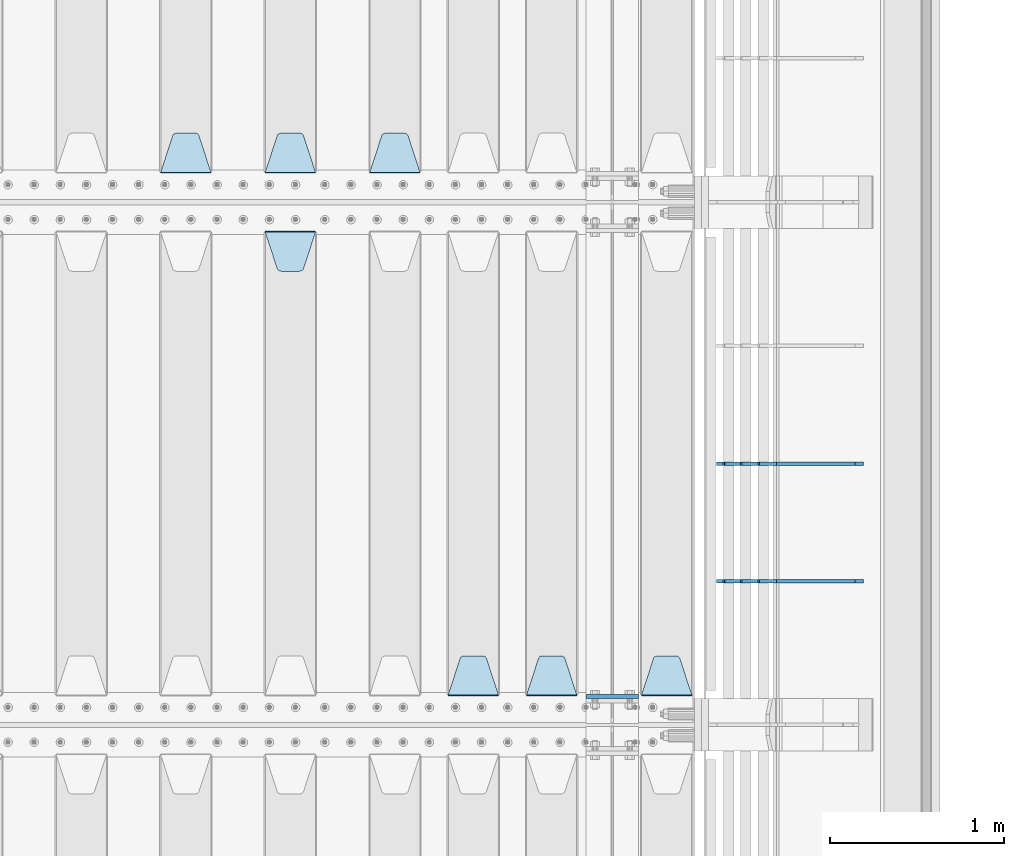
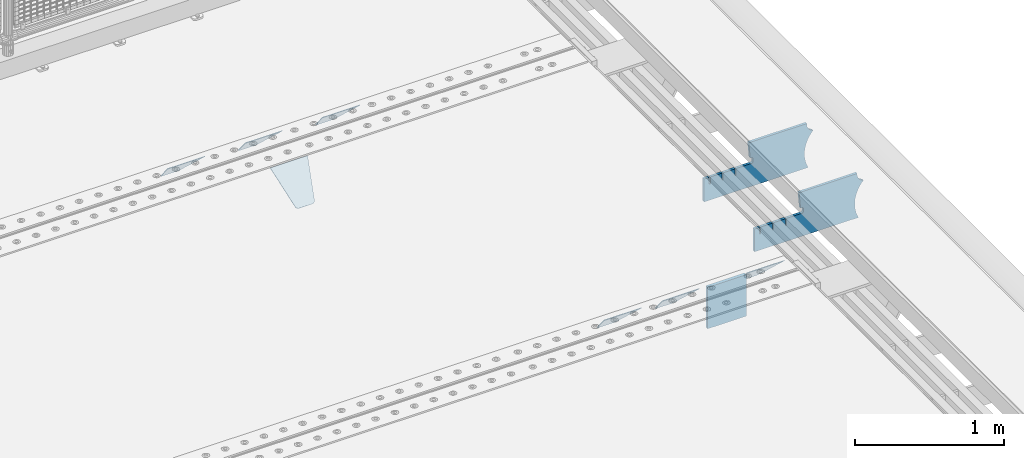
# One storey, part 246 of 270: 10 plates.
"""IFC2X3 building model written with IfcOpenShell, lengths in millimetres."""

from ifc_helpers import new_model, si_unit, frame, origin_with_axes, place, context, subcontext, project, spatial, faceted_brep, material, type_object, element, save


model = new_model("IFC2X3")

# Units and contexts
model_context = context("Model", 3, precision=1e-05, world=origin_with_axes())
body_context = subcontext(model_context, "Body", "Model", "MODEL_VIEW")
ifc_project = project(units=[si_unit("LENGTHUNIT", "METRE", prefix="MILLI"), si_unit("AREAUNIT", "SQUARE_METRE"), si_unit("VOLUMEUNIT", "CUBIC_METRE"), si_unit("MASSUNIT", "GRAM", prefix="KILO"), si_unit("TIMEUNIT", "SECOND"), si_unit("PLANEANGLEUNIT", "RADIAN"), si_unit("SOLIDANGLEUNIT", "STERADIAN"), si_unit("THERMODYNAMICTEMPERATUREUNIT", "DEGREE_CELSIUS"), si_unit("LUMINOUSINTENSITYUNIT", "LUMEN")], contexts=[model_context])

# Site, building, storey
site_placement = place(None, origin_with_axes())
site = spatial("IfcSite", under=ifc_project, at=site_placement, CompositionType="ELEMENT")
building_placement = place(site_placement, origin_with_axes())
building = spatial("IfcBuilding", under=site, at=building_placement, Name="Standard", CompositionType="ELEMENT")
storey_placement = place(building_placement, origin_with_axes())
storey = spatial("IfcBuildingStorey", under=building, at=storey_placement, Name="Undefined", CompositionType="ELEMENT", Elevation=0.0)

# Plates
ifc_material = material(Name="STEEL/S355N")
plate_type_1 = type_object("IfcPlateType", PredefinedType="NOTDEFINED")
plate_1_placement = place(storey_placement, frame((19768.0, -20837.5, -340.000000000044), z_axis=(0.0, 0.0, 1.0), x_axis=(1.0, 0.0, 0.0)))
element("IfcPlate", 1, at=plate_1_placement, inside=storey, type_object=plate_type_1, material=ifc_material, context=body_context, shape_type="Brep", body=[
    faceted_brep([(0.0, -12.5, 0.0), (9.27684595808387e-10, -12.5, 340.0), (9.27684595808387e-10, 12.5, 340.0), (0.0, 12.5, 0.0), (300.0, -12.5, 340.0), (300.0, 12.5, 340.0), (300.0, -12.5, 0.0), (300.0, 12.5, 0.0)], [[[0, 1, 2, 3]], [[1, 4, 5, 2]], [[4, 6, 7, 5]], [[6, 0, 3, 7]], [[5, 7, 3, 2]], [[6, 4, 1, 0]]]),
])
plate_type_2 = type_object("IfcPlateType", PredefinedType="NOTDEFINED")
plate_2_placement = place(storey_placement, frame((18815.0, -17831.767766953, -1.76776695296758), z_axis=(0.0, 0.707106781186547, -0.707106781186548), x_axis=(-1.0, 0.0, 0.0)))
element("IfcPlate", 2, at=plate_2_placement, inside=storey, type_object=plate_type_2, material=ifc_material, context=body_context, shape_type="Brep", body=[
    faceted_brep([(0.0, -2.5, 0.0), (69.345504679477, -2.5, 300.171731424831), (69.345504679477, 2.5, 300.171731424831), (0.0, 2.5, 0.0), (70.9274061199576, -2.5, 304.8974424154), (70.9274061199576, 2.5, 304.8974424154), (73.3818627772307, -2.49999999999818, 309.234538108527), (73.3818627772307, 2.50000000000182, 309.234538108527), (76.6187032999551, -2.5, 313.023683126103), (76.6187032999551, 2.5, 313.023683126103), (80.5190132704993, -2.5, 316.125672595372), (80.5190132704993, 2.50000000000182, 316.125672595372), (84.9395038596849, -2.49999999999818, 318.426546230476), (84.9395038596849, 2.5, 318.426546230476), (89.7177759439219, -2.49999999999818, 319.841774983275), (89.7177759439219, 2.50000000000182, 319.841774983275), (94.678286292652, -2.5, 320.319366455078), (94.678286292652, 2.5, 320.319366455078), (195.321713707348, -2.5, 320.319366455078), (195.321713707348, 2.5, 320.319366455078), (200.282224056078, -2.49999999999818, 319.841774983275), (200.282224056078, 2.50000000000182, 319.841774983275), (205.060496140315, -2.5, 318.426546230476), (205.060496140315, 2.5, 318.426546230476), (209.480986729501, -2.5, 316.12567259537), (209.480986729501, 2.50000000000182, 316.12567259537), (213.381296700045, -2.5, 313.023683126103), (213.381296700045, 2.5, 313.023683126103), (216.618137222769, -2.49999999999818, 309.234538108525), (216.618137222769, 2.50000000000182, 309.234538108527), (219.072593880042, -2.49999999999818, 304.897442415398), (219.072593880042, 2.50000000000182, 304.897442415397), (220.654495320523, -2.5, 300.171731424831), (220.654495320523, 2.5, 300.171731424831), (290.0, -2.49999999999818, 0.0), (290.0, 2.5, 0.0)], [[[0, 1, 2, 3]], [[1, 4, 5, 2]], [[4, 6, 7, 5]], [[6, 8, 9, 7]], [[8, 10, 11, 9]], [[10, 12, 13, 11]], [[12, 14, 15, 13]], [[14, 16, 17, 15]], [[16, 18, 19, 17]], [[18, 20, 21, 19]], [[20, 22, 23, 21]], [[22, 24, 25, 23]], [[24, 26, 27, 25]], [[26, 28, 29, 27]], [[28, 30, 31, 29]], [[30, 32, 33, 31]], [[32, 34, 35, 33]], [[34, 0, 3, 35]], [[5, 7, 9, 11, 13, 15, 17, 19, 21, 23, 25, 27, 29, 31, 33, 35, 3, 2]], [[34, 32, 30, 28, 26, 24, 22, 20, 18, 16, 14, 12, 10, 8, 6, 4, 1, 0]]]),
])
plate_3_placement = place(storey_placement, frame((18215.0, -17831.767766953, -1.76776695296758), z_axis=(0.0, 0.707106781186547, -0.707106781186548), x_axis=(-1.0, 0.0, 0.0)))
element("IfcPlate", 3, at=plate_3_placement, inside=storey, type_object=plate_type_2, material=ifc_material, context=body_context, shape_type="Brep", body=[
    faceted_brep([(0.0, -2.5, 0.0), (69.345504679477, -2.5, 300.171731424831), (69.345504679477, 2.5, 300.171731424831), (0.0, 2.5, 0.0), (70.9274061199576, -2.5, 304.8974424154), (70.9274061199576, 2.5, 304.8974424154), (73.3818627772307, -2.49999999999818, 309.234538108527), (73.3818627772307, 2.50000000000182, 309.234538108527), (76.6187032999551, -2.5, 313.023683126103), (76.6187032999551, 2.5, 313.023683126103), (80.5190132704993, -2.5, 316.125672595372), (80.5190132704993, 2.50000000000182, 316.125672595372), (84.9395038596849, -2.49999999999818, 318.426546230476), (84.9395038596849, 2.5, 318.426546230476), (89.7177759439219, -2.49999999999818, 319.841774983275), (89.7177759439219, 2.50000000000182, 319.841774983275), (94.678286292652, -2.5, 320.319366455078), (94.678286292652, 2.5, 320.319366455078), (195.321713707348, -2.5, 320.319366455078), (195.321713707348, 2.5, 320.319366455078), (200.282224056078, -2.49999999999818, 319.841774983275), (200.282224056078, 2.50000000000182, 319.841774983275), (205.060496140315, -2.5, 318.426546230476), (205.060496140315, 2.5, 318.426546230476), (209.480986729501, -2.5, 316.12567259537), (209.480986729501, 2.50000000000182, 316.12567259537), (213.381296700045, -2.5, 313.023683126103), (213.381296700045, 2.5, 313.023683126103), (216.618137222769, -2.49999999999818, 309.234538108525), (216.618137222769, 2.50000000000182, 309.234538108527), (219.072593880042, -2.49999999999818, 304.897442415398), (219.072593880042, 2.50000000000182, 304.897442415397), (220.654495320523, -2.5, 300.171731424831), (220.654495320523, 2.5, 300.171731424831), (290.0, -2.49999999999818, 0.0), (290.0, 2.5, 0.0)], [[[0, 1, 2, 3]], [[1, 4, 5, 2]], [[4, 6, 7, 5]], [[6, 8, 9, 7]], [[8, 10, 11, 9]], [[10, 12, 13, 11]], [[12, 14, 15, 13]], [[14, 16, 17, 15]], [[16, 18, 19, 17]], [[18, 20, 21, 19]], [[20, 22, 23, 21]], [[22, 24, 25, 23]], [[24, 26, 27, 25]], [[26, 28, 29, 27]], [[28, 30, 31, 29]], [[30, 32, 33, 31]], [[32, 34, 35, 33]], [[34, 0, 3, 35]], [[5, 7, 9, 11, 13, 15, 17, 19, 21, 23, 25, 27, 29, 31, 33, 35, 3, 2]], [[34, 32, 30, 28, 26, 24, 22, 20, 18, 16, 14, 12, 10, 8, 6, 4, 1, 0]]]),
])
plate_4_placement = place(storey_placement, frame((17615.0, -17831.767766953, -1.76776695296758), z_axis=(0.0, 0.707106781186547, -0.707106781186548), x_axis=(-1.0, 0.0, 0.0)))
element("IfcPlate", 4, at=plate_4_placement, inside=storey, type_object=plate_type_2, material=ifc_material, context=body_context, shape_type="Brep", body=[
    faceted_brep([(0.0, -2.5, 0.0), (69.345504679477, -2.5, 300.171731424831), (69.345504679477, 2.5, 300.171731424831), (0.0, 2.5, 0.0), (70.9274061199576, -2.5, 304.8974424154), (70.9274061199576, 2.5, 304.8974424154), (73.3818627772307, -2.49999999999818, 309.234538108527), (73.3818627772307, 2.50000000000182, 309.234538108527), (76.6187032999551, -2.5, 313.023683126103), (76.6187032999551, 2.5, 313.023683126103), (80.5190132704993, -2.5, 316.125672595372), (80.5190132704993, 2.50000000000182, 316.125672595372), (84.9395038596849, -2.49999999999818, 318.426546230476), (84.9395038596849, 2.5, 318.426546230476), (89.7177759439219, -2.49999999999818, 319.841774983275), (89.7177759439219, 2.50000000000182, 319.841774983275), (94.678286292652, -2.5, 320.319366455078), (94.678286292652, 2.5, 320.319366455078), (195.321713707348, -2.5, 320.319366455078), (195.321713707348, 2.5, 320.319366455078), (200.282224056078, -2.49999999999818, 319.841774983275), (200.282224056078, 2.50000000000182, 319.841774983275), (205.060496140315, -2.5, 318.426546230476), (205.060496140315, 2.5, 318.426546230476), (209.480986729501, -2.5, 316.12567259537), (209.480986729501, 2.50000000000182, 316.12567259537), (213.381296700045, -2.5, 313.023683126103), (213.381296700045, 2.5, 313.023683126103), (216.618137222769, -2.49999999999818, 309.234538108525), (216.618137222769, 2.50000000000182, 309.234538108527), (219.072593880042, -2.49999999999818, 304.897442415398), (219.072593880042, 2.50000000000182, 304.897442415397), (220.654495320523, -2.5, 300.171731424831), (220.654495320523, 2.5, 300.171731424831), (290.0, -2.49999999999818, 0.0), (290.0, 2.5, 0.0)], [[[0, 1, 2, 3]], [[1, 4, 5, 2]], [[4, 6, 7, 5]], [[6, 8, 9, 7]], [[8, 10, 11, 9]], [[10, 12, 13, 11]], [[12, 14, 15, 13]], [[14, 16, 17, 15]], [[16, 18, 19, 17]], [[18, 20, 21, 19]], [[20, 22, 23, 21]], [[22, 24, 25, 23]], [[24, 26, 27, 25]], [[26, 28, 29, 27]], [[28, 30, 31, 29]], [[30, 32, 33, 31]], [[32, 34, 35, 33]], [[34, 0, 3, 35]], [[5, 7, 9, 11, 13, 15, 17, 19, 21, 23, 25, 27, 29, 31, 33, 35, 3, 2]], [[34, 32, 30, 28, 26, 24, 22, 20, 18, 16, 14, 12, 10, 8, 6, 4, 1, 0]]]),
])
plate_5_placement = place(storey_placement, frame((20375.0, -20831.767766953, -1.76776695296758), z_axis=(0.0, 0.707106781186547, -0.707106781186548), x_axis=(-1.0, 0.0, 0.0)))
element("IfcPlate", 5, at=plate_5_placement, inside=storey, type_object=plate_type_2, material=ifc_material, context=body_context, shape_type="Brep", body=[
    faceted_brep([(0.0, -2.5, 0.0), (69.345504679477, -2.5, 300.171731424831), (69.345504679477, 2.5, 300.171731424831), (0.0, 2.5, 0.0), (70.9274061199576, -2.5, 304.8974424154), (70.9274061199576, 2.5, 304.8974424154), (73.3818627772307, -2.49999999999818, 309.234538108527), (73.3818627772307, 2.50000000000182, 309.234538108527), (76.6187032999551, -2.5, 313.023683126103), (76.6187032999551, 2.5, 313.023683126103), (80.5190132704993, -2.5, 316.125672595372), (80.5190132704993, 2.50000000000182, 316.125672595372), (84.9395038596849, -2.49999999999818, 318.426546230476), (84.9395038596849, 2.5, 318.426546230476), (89.7177759439219, -2.49999999999818, 319.841774983275), (89.7177759439219, 2.50000000000182, 319.841774983275), (94.678286292652, -2.5, 320.319366455078), (94.678286292652, 2.5, 320.319366455078), (195.321713707348, -2.5, 320.319366455078), (195.321713707348, 2.5, 320.319366455078), (200.282224056078, -2.49999999999818, 319.841774983275), (200.282224056078, 2.50000000000182, 319.841774983275), (205.060496140315, -2.5, 318.426546230476), (205.060496140315, 2.5, 318.426546230476), (209.480986729501, -2.5, 316.12567259537), (209.480986729501, 2.50000000000182, 316.12567259537), (213.381296700045, -2.5, 313.023683126103), (213.381296700045, 2.5, 313.023683126103), (216.618137222769, -2.49999999999818, 309.234538108525), (216.618137222769, 2.50000000000182, 309.234538108527), (219.072593880042, -2.49999999999818, 304.897442415398), (219.072593880042, 2.50000000000182, 304.897442415397), (220.654495320523, -2.5, 300.171731424831), (220.654495320523, 2.5, 300.171731424831), (290.0, -2.49999999999818, 0.0), (290.0, 2.5, 0.0)], [[[0, 1, 2, 3]], [[1, 4, 5, 2]], [[4, 6, 7, 5]], [[6, 8, 9, 7]], [[8, 10, 11, 9]], [[10, 12, 13, 11]], [[12, 14, 15, 13]], [[14, 16, 17, 15]], [[16, 18, 19, 17]], [[18, 20, 21, 19]], [[20, 22, 23, 21]], [[22, 24, 25, 23]], [[24, 26, 27, 25]], [[26, 28, 29, 27]], [[28, 30, 31, 29]], [[30, 32, 33, 31]], [[32, 34, 35, 33]], [[34, 0, 3, 35]], [[5, 7, 9, 11, 13, 15, 17, 19, 21, 23, 25, 27, 29, 31, 33, 35, 3, 2]], [[34, 32, 30, 28, 26, 24, 22, 20, 18, 16, 14, 12, 10, 8, 6, 4, 1, 0]]]),
])
plate_6_placement = place(storey_placement, frame((19715.0, -20831.767766953, -1.76776695296758), z_axis=(0.0, 0.707106781186547, -0.707106781186548), x_axis=(-1.0, 0.0, 0.0)))
element("IfcPlate", 6, at=plate_6_placement, inside=storey, type_object=plate_type_2, material=ifc_material, context=body_context, shape_type="Brep", body=[
    faceted_brep([(0.0, -2.5, 0.0), (69.345504679477, -2.5, 300.171731424831), (69.345504679477, 2.5, 300.171731424831), (0.0, 2.5, 0.0), (70.9274061199576, -2.5, 304.8974424154), (70.9274061199576, 2.5, 304.8974424154), (73.3818627772307, -2.49999999999818, 309.234538108527), (73.3818627772307, 2.50000000000182, 309.234538108527), (76.6187032999551, -2.5, 313.023683126103), (76.6187032999551, 2.5, 313.023683126103), (80.5190132704993, -2.5, 316.125672595372), (80.5190132704993, 2.50000000000182, 316.125672595372), (84.9395038596849, -2.49999999999818, 318.426546230476), (84.9395038596849, 2.5, 318.426546230476), (89.7177759439219, -2.49999999999818, 319.841774983275), (89.7177759439219, 2.50000000000182, 319.841774983275), (94.678286292652, -2.5, 320.319366455078), (94.678286292652, 2.5, 320.319366455078), (195.321713707348, -2.5, 320.319366455078), (195.321713707348, 2.5, 320.319366455078), (200.282224056078, -2.49999999999818, 319.841774983275), (200.282224056078, 2.50000000000182, 319.841774983275), (205.060496140315, -2.5, 318.426546230476), (205.060496140315, 2.5, 318.426546230476), (209.480986729501, -2.5, 316.12567259537), (209.480986729501, 2.50000000000182, 316.12567259537), (213.381296700045, -2.5, 313.023683126103), (213.381296700045, 2.5, 313.023683126103), (216.618137222769, -2.49999999999818, 309.234538108525), (216.618137222769, 2.50000000000182, 309.234538108527), (219.072593880042, -2.49999999999818, 304.897442415398), (219.072593880042, 2.50000000000182, 304.897442415397), (220.654495320523, -2.5, 300.171731424831), (220.654495320523, 2.5, 300.171731424831), (290.0, -2.49999999999818, 0.0), (290.0, 2.5, 0.0)], [[[0, 1, 2, 3]], [[1, 4, 5, 2]], [[4, 6, 7, 5]], [[6, 8, 9, 7]], [[8, 10, 11, 9]], [[10, 12, 13, 11]], [[12, 14, 15, 13]], [[14, 16, 17, 15]], [[16, 18, 19, 17]], [[18, 20, 21, 19]], [[20, 22, 23, 21]], [[22, 24, 25, 23]], [[24, 26, 27, 25]], [[26, 28, 29, 27]], [[28, 30, 31, 29]], [[30, 32, 33, 31]], [[32, 34, 35, 33]], [[34, 0, 3, 35]], [[5, 7, 9, 11, 13, 15, 17, 19, 21, 23, 25, 27, 29, 31, 33, 35, 3, 2]], [[34, 32, 30, 28, 26, 24, 22, 20, 18, 16, 14, 12, 10, 8, 6, 4, 1, 0]]]),
])
plate_7_placement = place(storey_placement, frame((19265.0, -20831.767766953, -1.76776695296758), z_axis=(0.0, 0.707106781186547, -0.707106781186548), x_axis=(-1.0, 0.0, 0.0)))
element("IfcPlate", 7, at=plate_7_placement, inside=storey, type_object=plate_type_2, material=ifc_material, context=body_context, shape_type="Brep", body=[
    faceted_brep([(0.0, -2.5, 0.0), (69.345504679477, -2.5, 300.171731424831), (69.345504679477, 2.5, 300.171731424831), (0.0, 2.5, 0.0), (70.9274061199576, -2.5, 304.8974424154), (70.9274061199576, 2.5, 304.8974424154), (73.3818627772307, -2.49999999999818, 309.234538108527), (73.3818627772307, 2.50000000000182, 309.234538108527), (76.6187032999551, -2.5, 313.023683126103), (76.6187032999551, 2.5, 313.023683126103), (80.5190132704993, -2.5, 316.125672595372), (80.5190132704993, 2.50000000000182, 316.125672595372), (84.9395038596849, -2.49999999999818, 318.426546230476), (84.9395038596849, 2.5, 318.426546230476), (89.7177759439219, -2.49999999999818, 319.841774983275), (89.7177759439219, 2.50000000000182, 319.841774983275), (94.678286292652, -2.5, 320.319366455078), (94.678286292652, 2.5, 320.319366455078), (195.321713707348, -2.5, 320.319366455078), (195.321713707348, 2.5, 320.319366455078), (200.282224056078, -2.49999999999818, 319.841774983275), (200.282224056078, 2.50000000000182, 319.841774983275), (205.060496140315, -2.5, 318.426546230476), (205.060496140315, 2.5, 318.426546230476), (209.480986729501, -2.5, 316.12567259537), (209.480986729501, 2.50000000000182, 316.12567259537), (213.381296700045, -2.5, 313.023683126103), (213.381296700045, 2.5, 313.023683126103), (216.618137222769, -2.49999999999818, 309.234538108525), (216.618137222769, 2.50000000000182, 309.234538108527), (219.072593880042, -2.49999999999818, 304.897442415398), (219.072593880042, 2.50000000000182, 304.897442415397), (220.654495320523, -2.5, 300.171731424831), (220.654495320523, 2.5, 300.171731424831), (290.0, -2.49999999999818, 0.0), (290.0, 2.5, 0.0)], [[[0, 1, 2, 3]], [[1, 4, 5, 2]], [[4, 6, 7, 5]], [[6, 8, 9, 7]], [[8, 10, 11, 9]], [[10, 12, 13, 11]], [[12, 14, 15, 13]], [[14, 16, 17, 15]], [[16, 18, 19, 17]], [[18, 20, 21, 19]], [[20, 22, 23, 21]], [[22, 24, 25, 23]], [[24, 26, 27, 25]], [[26, 28, 29, 27]], [[28, 30, 31, 29]], [[30, 32, 33, 31]], [[32, 34, 35, 33]], [[34, 0, 3, 35]], [[5, 7, 9, 11, 13, 15, 17, 19, 21, 23, 25, 27, 29, 31, 33, 35, 3, 2]], [[34, 32, 30, 28, 26, 24, 22, 20, 18, 16, 14, 12, 10, 8, 6, 4, 1, 0]]]),
])
plate_8_placement = place(storey_placement, frame((17925.0, -18168.232233044, -1.76776695296576), z_axis=(0.0, -0.707106781186548, -0.707106781186547), x_axis=(1.0, 0.0, 0.0)))
element("IfcPlate", 8, at=plate_8_placement, inside=storey, type_object=plate_type_2, material=ifc_material, context=body_context, shape_type="Brep", body=[
    faceted_brep([(0.0, -2.5, 0.0), (69.345504679477, -2.5, 300.171731424831), (69.345504679477, 2.5, 300.171731424831), (0.0, 2.5, 0.0), (70.9274061199576, -2.5, 304.8974424154), (70.9274061199576, 2.5, 304.8974424154), (73.3818627772307, -2.49999999999818, 309.234538108527), (73.3818627772307, 2.50000000000182, 309.234538108527), (76.6187032999551, -2.5, 313.023683126103), (76.6187032999551, 2.5, 313.023683126103), (80.5190132704993, -2.5, 316.125672595372), (80.5190132704993, 2.50000000000182, 316.125672595372), (84.9395038596849, -2.49999999999818, 318.426546230476), (84.9395038596849, 2.5, 318.426546230476), (89.7177759439219, -2.49999999999818, 319.841774983275), (89.7177759439219, 2.50000000000182, 319.841774983275), (94.678286292652, -2.5, 320.319366455078), (94.678286292652, 2.5, 320.319366455078), (195.321713707348, -2.5, 320.319366455078), (195.321713707348, 2.5, 320.319366455078), (200.282224056078, -2.49999999999818, 319.841774983275), (200.282224056078, 2.50000000000182, 319.841774983275), (205.060496140315, -2.5, 318.426546230476), (205.060496140315, 2.5, 318.426546230476), (209.480986729501, -2.5, 316.12567259537), (209.480986729501, 2.50000000000182, 316.12567259537), (213.381296700045, -2.5, 313.023683126103), (213.381296700045, 2.5, 313.023683126103), (216.618137222769, -2.49999999999818, 309.234538108525), (216.618137222769, 2.50000000000182, 309.234538108527), (219.072593880042, -2.49999999999818, 304.897442415398), (219.072593880042, 2.50000000000182, 304.897442415397), (220.654495320523, -2.5, 300.171731424831), (220.654495320523, 2.5, 300.171731424831), (290.0, -2.49999999999818, 0.0), (290.0, 2.5, 0.0)], [[[0, 1, 2, 3]], [[1, 4, 5, 2]], [[4, 6, 7, 5]], [[6, 8, 9, 7]], [[8, 10, 11, 9]], [[10, 12, 13, 11]], [[12, 14, 15, 13]], [[14, 16, 17, 15]], [[16, 18, 19, 17]], [[18, 20, 21, 19]], [[20, 22, 23, 21]], [[22, 24, 25, 23]], [[24, 26, 27, 25]], [[26, 28, 29, 27]], [[28, 30, 31, 29]], [[30, 32, 33, 31]], [[32, 34, 35, 33]], [[34, 0, 3, 35]], [[5, 7, 9, 11, 13, 15, 17, 19, 21, 23, 25, 27, 29, 31, 33, 35, 3, 2]], [[34, 32, 30, 28, 26, 24, 22, 20, 18, 16, 14, 12, 10, 8, 6, 4, 1, 0]]]),
])
plate_type_3 = type_object("IfcPlateType", PredefinedType="NOTDEFINED")
plate_9_placement = place(storey_placement, frame((21355.9182339676, -20175.0007171631, -374.002067436517), z_axis=(0.0, 0.0, 1.0), x_axis=(-1.0, 0.0, 0.0)))
element("IfcPlate", 9, at=plate_9_placement, inside=storey, type_object=plate_type_3, material=ifc_material, context=body_context, shape_type="Brep", body=[
    faceted_brep([(801.919404066546, -10.0, 188.0), (801.919404066546, 10.0, 188.0), (801.919404066546, 10.0, 132.002067436952), (801.919404066546, -10.0, 132.002067436952), (793.919404066546, 10.0, 132.002067436952), (793.919404066546, -10.0, 132.002067436952), (793.919404066546, 10.0, 180.002067436952), (793.919404066546, -10.0, 180.002067436952), (793.527856196906, 10.0, 182.474203391951), (793.527856196906, -10.0, 182.474203391951), (792.391540021545, 10.0, 184.704349455291), (792.391540021545, -10.0, 184.704349455291), (790.621686084887, 10.0, 186.474203391951), (790.621686084887, -10.0, 186.474203391951), (788.391540021545, 10.0, 187.610519567313), (788.391540021545, -10.0, 187.610519567313), (785.919404066546, -10.0, 188.002067436952), (785.919404066546, 10.0, 188.0), (841.0, -10.0, 188.0), (841.0, -10.0, 0.0), (841.0, 10.0, 0.0), (841.0, 10.0, 188.0), (33.3619566735979, -10.0, 0.0), (33.3619566735979, 10.0, 0.0), (36.2350612208174, -10.0, 4.68848050267013), (36.2350612208174, 10.0, 4.68848050267013), (51.4877592159428, -10.0, 41.5117508652784), (51.4877592159428, 10.0, 41.5117508652784), (60.792242588137, -10.0, 80.2677133162964), (60.792242588137, 10.0, 80.2677133162964), (63.9194040769726, -10.0, 120.002067436515), (63.9194040769726, 10.0, 120.002067436515), (60.792242588137, -10.0, 159.736421556734), (60.792242588137, 10.0, 159.736421556734), (51.4877592159428, -10.0, 198.492384007752), (51.4877592159428, 10.0, 198.492384007752), (36.2350612208174, -10.0, 235.31565437036), (36.2350612208174, 10.0, 235.31565437036), (15.4097206482074, -10.0, 269.299521518803), (15.4097206482074, 10.0, 269.299521518803), (-3.35474438098754, -10.0, 291.269887256574), (-3.35474438098754, 10.0, 291.269887256574), (-2.36881039375294, -10.0, 291.426043859339), (-2.36881039375294, 10.0, 291.426043859339), (17.1449676604716, -10.0, 301.368810393754), (17.1449676604716, 10.0, 301.368810393754), (32.6311896062471, -10.0, 316.855032339527), (32.6311896062471, 10.0, 316.855032339527), (42.573956140659, -10.0, 336.368810393754), (42.573956140659, 10.0, 336.368810393754), (46.0, -10.0, 358.0), (46.0, 10.0, 358.0), (45.0495205499174, -10.0, 364.001091067617), (45.0495205499174, 10.0, 364.001091067617), (495.040008544922, -10.0, 364.010009765625), (495.040008544922, 10.0, 364.010009765625), (483.600036621094, -10.0, 233.759994506836), (483.600036621094, 10.0, 233.759994506836), (472.0, -10.0, 233.759994506836), (472.0, 10.0, 233.759994506836), (468.909830056251, -10.0, 233.270559669787), (468.909830056251, 10.0, 233.270559669787), (466.122147477075, -10.0, 231.850164450585), (466.122147477075, 10.0, 231.850164450585), (463.909830056251, -10.0, 229.637847029761), (463.909830056251, 10.0, 229.637847029761), (462.489434837047, -10.0, 226.850164450585), (462.489434837047, 10.0, 226.850164450585), (462.0, -10.0, 223.759994506836), (462.0, 10.0, 223.759994506836), (462.0, -10.0, 198.0), (462.0, 10.0, 198.0), (462.489434837047, -10.0, 194.909830056251), (462.489434837047, 10.0, 194.909830056251), (463.909830056251, -10.0, 192.122147477075), (463.909830056251, 10.0, 192.122147477075), (466.122147477075, -10.0, 189.909830056251), (466.122147477075, 10.0, 189.909830056251), (468.909830056251, -10.0, 188.489434837048), (468.909830056251, 10.0, 188.489434837048), (472.0, -10.0, 188.0), (472.0, 10.0, 188.0), (585.919404066546, -10.0, 188.002067436952), (585.919404066546, 10.0, 188.0), (588.391540021545, -10.0, 187.610519567313), (588.391540021545, 10.0, 187.610519567313), (590.621686084887, -10.0, 186.474203391951), (590.621686084887, 10.0, 186.474203391951), (592.391540021545, -10.0, 184.704349455291), (592.391540021545, 10.0, 184.704349455291), (593.527856196906, -10.0, 182.474203391951), (593.527856196906, 10.0, 182.474203391951), (593.919404066546, -10.0, 180.002067436952), (593.919404066546, 10.0, 180.002067436952), (593.919404066546, -10.0000000000036, 132.002067436952), (593.919404066546, 10.0, 132.002067436952), (601.919404066546, -10.0000000000036, 132.002067436952), (601.919404066546, 10.0, 132.002067436952), (601.919404066546, -10.0, 188.0), (601.919404066546, 10.0, 188.0), (685.919404066546, -10.0, 188.002067436952), (685.919404066546, 10.0, 188.0), (688.391540021545, -10.0, 187.610519567313), (688.391540021545, 10.0, 187.610519567313), (690.621686084887, -10.0, 186.474203391951), (690.621686084887, 10.0, 186.474203391951), (692.391540021545, -10.0, 184.704349455291), (692.391540021545, 10.0, 184.704349455291), (693.527856196906, -10.0, 182.474203391951), (693.527856196906, 10.0, 182.474203391951), (693.919404066546, -10.0, 180.002067436952), (693.919404066546, 10.0, 180.002067436952), (693.919404066546, -10.0, 132.002067436952), (693.919404066546, 10.0, 132.002067436952), (701.919404066546, -10.0, 132.002067436952), (701.919404066546, 10.0, 132.002067436952), (701.919404066546, -10.0, 188.0), (701.919404066546, 10.0, 188.0)], [[[0, 1, 2, 3]], [[3, 2, 4, 5]], [[5, 4, 6, 7]], [[7, 6, 8, 9]], [[9, 8, 10, 11]], [[11, 10, 12, 13]], [[13, 12, 14, 15]], [[16, 15, 14, 17]], [[18, 19, 20, 21]], [[20, 19, 22, 23]], [[22, 24, 25, 23]], [[26, 27, 25, 24]], [[28, 29, 27, 26]], [[30, 31, 29, 28]], [[32, 33, 31, 30]], [[34, 35, 33, 32]], [[36, 37, 35, 34]], [[38, 39, 37, 36]], [[39, 38, 40, 41]], [[40, 42, 43, 41]], [[44, 45, 43, 42]], [[46, 47, 45, 44]], [[48, 49, 47, 46]], [[50, 51, 49, 48]], [[52, 53, 51, 50]], [[54, 55, 53, 52]], [[54, 56, 57, 55]], [[56, 58, 59, 57]], [[58, 60, 61, 59]], [[60, 62, 63, 61]], [[62, 64, 65, 63]], [[64, 66, 67, 65]], [[66, 68, 69, 67]], [[68, 70, 71, 69]], [[70, 72, 73, 71]], [[72, 74, 75, 73]], [[74, 76, 77, 75]], [[76, 78, 79, 77]], [[78, 80, 81, 79]], [[81, 80, 82, 83]], [[82, 84, 85, 83]], [[86, 87, 85, 84]], [[88, 89, 87, 86]], [[90, 91, 89, 88]], [[92, 93, 91, 90]], [[94, 95, 93, 92]], [[96, 97, 95, 94]], [[98, 99, 97, 96]], [[99, 98, 100, 101]], [[100, 102, 103, 101]], [[104, 105, 103, 102]], [[106, 107, 105, 104]], [[108, 109, 107, 106]], [[110, 111, 109, 108]], [[112, 113, 111, 110]], [[114, 115, 113, 112]], [[116, 117, 115, 114]], [[117, 116, 16, 17]], [[12, 10, 8, 6, 4, 2, 1, 21, 20, 23, 25, 27, 29, 31, 33, 35, 37, 39, 41, 43, 45, 47, 49, 51, 53, 55, 57, 59, 61, 63, 65, 67, 69, 71, 73, 75, 77, 79, 81, 83, 85, 87, 89, 91, 93, 95, 97, 99, 101, 103, 105, 107, 109, 111, 113, 115, 117, 17, 14]], [[18, 21, 1, 0]], [[116, 114, 112, 110, 108, 106, 104, 102, 100, 98, 96, 94, 92, 90, 88, 86, 84, 82, 80, 78, 76, 74, 72, 70, 68, 66, 64, 62, 60, 58, 56, 54, 52, 50, 48, 46, 44, 42, 40, 38, 36, 34, 32, 30, 28, 26, 24, 22, 19, 18, 0, 3, 5, 7, 9, 11, 13, 15, 16]]]),
])
plate_10_placement = place(storey_placement, frame((21355.9182339676, -19500.0007171631, -374.002067436517), z_axis=(0.0, 0.0, 1.0), x_axis=(-1.0, 0.0, 0.0)))
element("IfcPlate", 10, at=plate_10_placement, inside=storey, type_object=plate_type_3, material=ifc_material, context=body_context, shape_type="Brep", body=[
    faceted_brep([(801.919404066546, -10.0, 188.0), (801.919404066546, 10.0, 188.0), (801.919404066546, 10.0, 132.002067436952), (801.919404066546, -10.0, 132.002067436952), (793.919404066546, 10.0, 132.002067436952), (793.919404066546, -10.0, 132.002067436952), (793.919404066546, 10.0, 180.002067436952), (793.919404066546, -10.0, 180.002067436952), (793.527856196906, 10.0, 182.474203391951), (793.527856196906, -10.0, 182.474203391951), (792.391540021545, 10.0, 184.704349455291), (792.391540021545, -10.0, 184.704349455291), (790.621686084887, 10.0, 186.474203391951), (790.621686084887, -10.0, 186.474203391951), (788.391540021545, 10.0, 187.610519567313), (788.391540021545, -10.0, 187.610519567313), (785.919404066546, -10.0, 188.002067436952), (785.919404066546, 10.0, 188.0), (841.0, -10.0, 188.0), (841.0, -10.0, 0.0), (841.0, 10.0, 0.0), (841.0, 10.0, 188.0), (33.3619566735979, -10.0, 0.0), (33.3619566735979, 10.0, 0.0), (36.2350612208174, -10.0, 4.68848050267013), (36.2350612208174, 10.0, 4.68848050267013), (51.4877592159428, -10.0, 41.5117508652784), (51.4877592159428, 10.0, 41.5117508652784), (60.792242588137, -10.0, 80.2677133162964), (60.792242588137, 10.0, 80.2677133162964), (63.9194040769726, -10.0, 120.002067436515), (63.9194040769726, 10.0, 120.002067436515), (60.792242588137, -10.0, 159.736421556734), (60.792242588137, 10.0, 159.736421556734), (51.4877592159428, -10.0, 198.492384007752), (51.4877592159428, 10.0, 198.492384007752), (36.2350612208174, -10.0, 235.31565437036), (36.2350612208174, 10.0, 235.31565437036), (15.4097206482074, -10.0, 269.299521518803), (15.4097206482074, 10.0, 269.299521518803), (-3.35474438098754, -10.0, 291.269887256574), (-3.35474438098754, 10.0, 291.269887256574), (-2.36881039375294, -10.0, 291.426043859339), (-2.36881039375294, 10.0, 291.426043859339), (17.1449676604716, -10.0, 301.368810393754), (17.1449676604716, 10.0, 301.368810393754), (32.6311896062471, -10.0, 316.855032339527), (32.6311896062471, 10.0, 316.855032339527), (42.573956140659, -10.0, 336.368810393754), (42.573956140659, 10.0, 336.368810393754), (46.0, -10.0, 358.0), (46.0, 10.0, 358.0), (45.0495205499174, -10.0, 364.001091067617), (45.0495205499174, 10.0, 364.001091067617), (495.040008544922, -10.0, 364.010009765625), (495.040008544922, 10.0, 364.010009765625), (483.600036621094, -10.0, 233.759994506836), (483.600036621094, 10.0, 233.759994506836), (472.0, -10.0, 233.759994506836), (472.0, 10.0, 233.759994506836), (468.909830056251, -10.0, 233.270559669787), (468.909830056251, 10.0, 233.270559669787), (466.122147477075, -10.0, 231.850164450585), (466.122147477075, 10.0, 231.850164450585), (463.909830056251, -10.0, 229.637847029761), (463.909830056251, 10.0, 229.637847029761), (462.489434837047, -10.0, 226.850164450585), (462.489434837047, 10.0, 226.850164450585), (462.0, -10.0, 223.759994506836), (462.0, 10.0, 223.759994506836), (462.0, -10.0, 198.0), (462.0, 10.0, 198.0), (462.489434837047, -10.0, 194.909830056251), (462.489434837047, 10.0, 194.909830056251), (463.909830056251, -10.0, 192.122147477075), (463.909830056251, 10.0, 192.122147477075), (466.122147477075, -10.0, 189.909830056251), (466.122147477075, 10.0, 189.909830056251), (468.909830056251, -10.0, 188.489434837048), (468.909830056251, 10.0, 188.489434837048), (472.0, -10.0, 188.0), (472.0, 10.0, 188.0), (585.919404066546, -10.0, 188.002067436952), (585.919404066546, 10.0, 188.0), (588.391540021545, -10.0, 187.610519567313), (588.391540021545, 10.0, 187.610519567313), (590.621686084887, -10.0, 186.474203391951), (590.621686084887, 10.0, 186.474203391951), (592.391540021545, -10.0, 184.704349455291), (592.391540021545, 10.0, 184.704349455291), (593.527856196906, -10.0, 182.474203391951), (593.527856196906, 10.0, 182.474203391951), (593.919404066546, -10.0, 180.002067436952), (593.919404066546, 10.0, 180.002067436952), (593.919404066546, -10.0000000000036, 132.002067436952), (593.919404066546, 10.0, 132.002067436952), (601.919404066546, -10.0000000000036, 132.002067436952), (601.919404066546, 10.0, 132.002067436952), (601.919404066546, -10.0, 188.0), (601.919404066546, 10.0, 188.0), (685.919404066546, -10.0, 188.002067436952), (685.919404066546, 10.0, 188.0), (688.391540021545, -10.0, 187.610519567313), (688.391540021545, 10.0, 187.610519567313), (690.621686084887, -10.0, 186.474203391951), (690.621686084887, 10.0, 186.474203391951), (692.391540021545, -10.0, 184.704349455291), (692.391540021545, 10.0, 184.704349455291), (693.527856196906, -10.0, 182.474203391951), (693.527856196906, 10.0, 182.474203391951), (693.919404066546, -10.0, 180.002067436952), (693.919404066546, 10.0, 180.002067436952), (693.919404066546, -10.0, 132.002067436952), (693.919404066546, 10.0, 132.002067436952), (701.919404066546, -10.0, 132.002067436952), (701.919404066546, 10.0, 132.002067436952), (701.919404066546, -10.0, 188.0), (701.919404066546, 10.0, 188.0)], [[[0, 1, 2, 3]], [[3, 2, 4, 5]], [[5, 4, 6, 7]], [[7, 6, 8, 9]], [[9, 8, 10, 11]], [[11, 10, 12, 13]], [[13, 12, 14, 15]], [[16, 15, 14, 17]], [[18, 19, 20, 21]], [[20, 19, 22, 23]], [[22, 24, 25, 23]], [[26, 27, 25, 24]], [[28, 29, 27, 26]], [[30, 31, 29, 28]], [[32, 33, 31, 30]], [[34, 35, 33, 32]], [[36, 37, 35, 34]], [[38, 39, 37, 36]], [[39, 38, 40, 41]], [[40, 42, 43, 41]], [[44, 45, 43, 42]], [[46, 47, 45, 44]], [[48, 49, 47, 46]], [[50, 51, 49, 48]], [[52, 53, 51, 50]], [[54, 55, 53, 52]], [[54, 56, 57, 55]], [[56, 58, 59, 57]], [[58, 60, 61, 59]], [[60, 62, 63, 61]], [[62, 64, 65, 63]], [[64, 66, 67, 65]], [[66, 68, 69, 67]], [[68, 70, 71, 69]], [[70, 72, 73, 71]], [[72, 74, 75, 73]], [[74, 76, 77, 75]], [[76, 78, 79, 77]], [[78, 80, 81, 79]], [[81, 80, 82, 83]], [[82, 84, 85, 83]], [[86, 87, 85, 84]], [[88, 89, 87, 86]], [[90, 91, 89, 88]], [[92, 93, 91, 90]], [[94, 95, 93, 92]], [[96, 97, 95, 94]], [[98, 99, 97, 96]], [[99, 98, 100, 101]], [[100, 102, 103, 101]], [[104, 105, 103, 102]], [[106, 107, 105, 104]], [[108, 109, 107, 106]], [[110, 111, 109, 108]], [[112, 113, 111, 110]], [[114, 115, 113, 112]], [[116, 117, 115, 114]], [[117, 116, 16, 17]], [[12, 10, 8, 6, 4, 2, 1, 21, 20, 23, 25, 27, 29, 31, 33, 35, 37, 39, 41, 43, 45, 47, 49, 51, 53, 55, 57, 59, 61, 63, 65, 67, 69, 71, 73, 75, 77, 79, 81, 83, 85, 87, 89, 91, 93, 95, 97, 99, 101, 103, 105, 107, 109, 111, 113, 115, 117, 17, 14]], [[18, 21, 1, 0]], [[116, 114, 112, 110, 108, 106, 104, 102, 100, 98, 96, 94, 92, 90, 88, 86, 84, 82, 80, 78, 76, 74, 72, 70, 68, 66, 64, 62, 60, 58, 56, 54, 52, 50, 48, 46, 44, 42, 40, 38, 36, 34, 32, 30, 28, 26, 24, 22, 19, 18, 0, 3, 5, 7, 9, 11, 13, 15, 16]]]),
])

save(model, "model.ifc")
